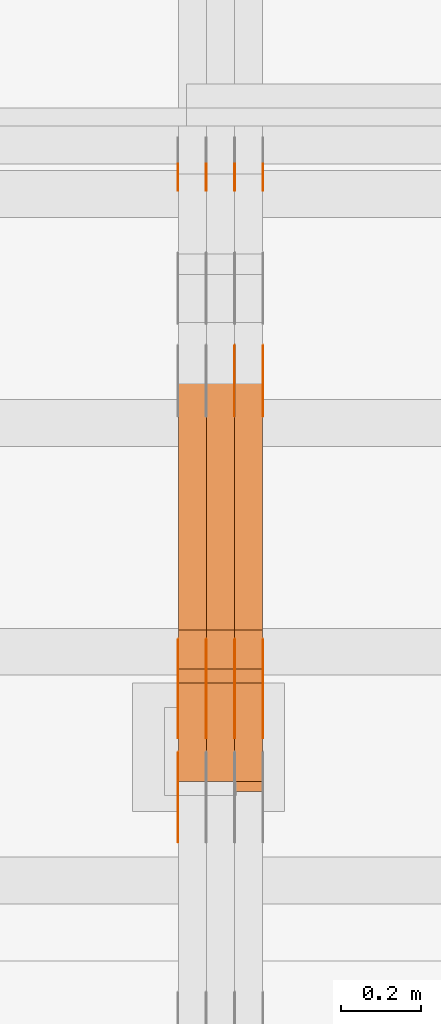
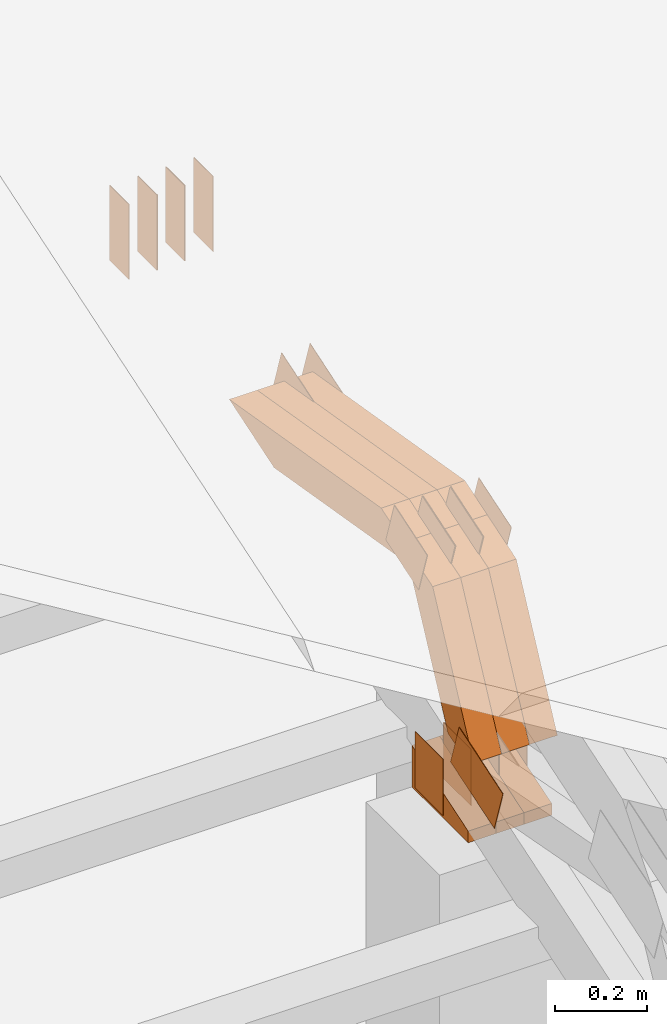
# One storey, part 295 of 385: 30 proxies.
"""IFC2X3 building model written with IfcOpenShell, lengths in millimetres."""

from ifc_helpers import new_model, entity, si_unit, converted_unit, derived_unit, direction, frame, frame_2d, origin, place, context, subcontext, project, spatial, polyline, rectangle, outline, extrude, source, transform, mapped, material, type_object, type_shapes, element, save


model = new_model("IFC2X3")

# Units and contexts
model_context = context("Model", 3, precision=0.01, world=origin(), true_north=direction((6.12303176911189e-17, 1.0)))
body_context = subcontext(model_context, "Body", "Model", "MODEL_VIEW")
ifc_project = project(units=[si_unit("LENGTHUNIT", "METRE", prefix="MILLI"), si_unit("AREAUNIT", "SQUARE_METRE"), si_unit("VOLUMEUNIT", "CUBIC_METRE"), converted_unit("PLANEANGLEUNIT", "DEGREE", entity("IfcRatioMeasure", 0.0174532925199433), si_unit("PLANEANGLEUNIT", "RADIAN"), dimensions=[0, 0, 0, 0, 0, 0, 0]), si_unit("MASSUNIT", "GRAM", prefix="KILO"), derived_unit("MASSDENSITYUNIT", [(si_unit("MASSUNIT", "GRAM", prefix="KILO"), 1), (si_unit("LENGTHUNIT", "METRE"), -3)]), si_unit("TIMEUNIT", "SECOND"), si_unit("FREQUENCYUNIT", "HERTZ"), si_unit("THERMODYNAMICTEMPERATUREUNIT", "DEGREE_CELSIUS"), derived_unit("THERMALTRANSMITTANCEUNIT", [(si_unit("MASSUNIT", "GRAM", prefix="KILO"), 1), (si_unit("THERMODYNAMICTEMPERATUREUNIT", "KELVIN"), -1), (si_unit("TIMEUNIT", "SECOND"), -3)]), derived_unit("VOLUMETRICFLOWRATEUNIT", [(si_unit("LENGTHUNIT", "METRE"), 3), (si_unit("TIMEUNIT", "SECOND"), -1)]), si_unit("ELECTRICCURRENTUNIT", "AMPERE"), si_unit("ELECTRICVOLTAGEUNIT", "VOLT"), si_unit("POWERUNIT", "WATT"), si_unit("FORCEUNIT", "NEWTON", prefix="KILO"), si_unit("ILLUMINANCEUNIT", "LUX"), si_unit("LUMINOUSFLUXUNIT", "LUMEN"), si_unit("LUMINOUSINTENSITYUNIT", "CANDELA"), derived_unit("USERDEFINED", [(si_unit("MASSUNIT", "GRAM", prefix="KILO"), -1), (si_unit("LENGTHUNIT", "METRE"), -2), (si_unit("TIMEUNIT", "SECOND"), 3), (si_unit("LUMINOUSFLUXUNIT", "LUMEN"), 1)]), derived_unit("LINEARVELOCITYUNIT", [(si_unit("LENGTHUNIT", "METRE"), 1), (si_unit("TIMEUNIT", "SECOND"), -1)]), si_unit("PRESSUREUNIT", "PASCAL"), derived_unit("USERDEFINED", [(si_unit("LENGTHUNIT", "METRE"), -2), (si_unit("MASSUNIT", "GRAM", prefix="KILO"), 1), (si_unit("TIMEUNIT", "SECOND"), -2)])], contexts=[model_context])

# Site, building, storey
site_placement = place(None, origin())
site = spatial("IfcSite", under=ifc_project, at=site_placement, CompositionType="ELEMENT")
building_placement = place(site_placement, origin())
building = spatial("IfcBuilding", under=site, at=building_placement, CompositionType="ELEMENT")
storey_placement = place(building_placement, origin())
storey = spatial("IfcBuildingStorey", under=building, at=storey_placement, Name="Default", CompositionType="ELEMENT", Elevation=0.0)

# Proxies
ifc_material_1 = material(Name="IfcSurfaceStyle #519028")
building_element_proxy_type_1 = type_object("IfcBuildingElementProxyType", PredefinedType="NOTDEFINED", material=ifc_material_1)
shared_shape_1 = source(origin(), body_context, "Body", "SweptSolid", [
    extrude(rectangle(XDim=200.0, YDim=84.0, at=frame_2d((0.0, -7.105427357601e-15), x_axis=(1.0, 0.0))), frame((100.0, 42.0, 0.0), z_axis=(0.0, 0.0, 1.0), x_axis=(-1.0, 0.0, 0.0)), (0.0, 0.0, 1.0), 1.3),
])
type_shapes(building_element_proxy_type_1, [shared_shape_1])
proxy_1_placement = place(building_placement, frame((42386.3, 13702.0, 3651.4150390625), z_axis=(-1.0, 0.0, 0.0), x_axis=(0.0, 0.0, -1.0)))
element("IfcBuildingElementProxy", 1, at=proxy_1_placement, inside=storey, type_object=building_element_proxy_type_1, material=ifc_material_1, context=body_context, shape_type="MappedRepresentation", body=[
    mapped(shared_shape_1, transform((0.0, 0.0, 0.0), scale=1.0)),
])
ifc_material_2 = material(Name="IfcSurfaceStyle #518971")
building_element_proxy_type_2 = type_object("IfcBuildingElementProxyType", PredefinedType="NOTDEFINED", material=ifc_material_2)
shared_shape_2 = source(origin(), body_context, "Body", "SweptSolid", [
    extrude(rectangle(XDim=200.0, YDim=84.0, at=frame_2d((0.0, -7.105427357601e-15), x_axis=(1.0, 0.0))), frame((100.0, 42.0, 0.0), z_axis=(0.0, 0.0, 1.0), x_axis=(-1.0, 0.0, 0.0)), (0.0, 0.0, 1.0), 1.3),
])
type_shapes(building_element_proxy_type_2, [shared_shape_2])
proxy_2_placement = place(building_placement, frame((42315.0, 13702.0, 3651.4150390625), z_axis=(-1.0, 0.0, 0.0), x_axis=(0.0, 0.0, -1.0)))
element("IfcBuildingElementProxy", 2, at=proxy_2_placement, inside=storey, type_object=building_element_proxy_type_2, material=ifc_material_2, context=body_context, shape_type="MappedRepresentation", body=[
    mapped(shared_shape_2, transform((0.0, 0.0, 0.0), scale=1.0)),
])
ifc_material_3 = material(Name="IfcSurfaceStyle #518914")
building_element_proxy_type_3 = type_object("IfcBuildingElementProxyType", PredefinedType="NOTDEFINED", material=ifc_material_3)
shared_shape_3 = source(origin(), body_context, "Body", "SweptSolid", [
    extrude(rectangle(XDim=200.0, YDim=84.0, at=frame_2d((0.0, -7.105427357601e-15), x_axis=(1.0, 0.0))), frame((100.0, 42.0, 0.0), z_axis=(0.0, 0.0, 1.0), x_axis=(-1.0, 0.0, 0.0)), (0.0, 0.0, 1.0), 1.3),
])
type_shapes(building_element_proxy_type_3, [shared_shape_3])
proxy_3_placement = place(building_placement, frame((42316.3, 13702.0, 3651.4150390625), z_axis=(-1.0, 0.0, 0.0), x_axis=(0.0, 0.0, -1.0)))
element("IfcBuildingElementProxy", 3, at=proxy_3_placement, inside=storey, type_object=building_element_proxy_type_3, material=ifc_material_3, context=body_context, shape_type="MappedRepresentation", body=[
    mapped(shared_shape_3, transform((0.0, 0.0, 0.0), scale=1.0)),
])
ifc_material_4 = material(Name="IfcSurfaceStyle #518857")
building_element_proxy_type_4 = type_object("IfcBuildingElementProxyType", PredefinedType="NOTDEFINED", material=ifc_material_4)
shared_shape_4 = source(origin(), body_context, "Body", "SweptSolid", [
    extrude(rectangle(XDim=200.0, YDim=84.0, at=frame_2d((0.0, -7.105427357601e-15), x_axis=(1.0, 0.0))), frame((100.0, 42.0, 0.0), z_axis=(0.0, 0.0, 1.0), x_axis=(-1.0, 0.0, 0.0)), (0.0, 0.0, 1.0), 1.29999999999998),
])
type_shapes(building_element_proxy_type_4, [shared_shape_4])
proxy_4_placement = place(building_placement, frame((42245.0, 13702.0, 3651.4150390625), z_axis=(-1.0, 0.0, 0.0), x_axis=(0.0, 0.0, -1.0)))
element("IfcBuildingElementProxy", 4, at=proxy_4_placement, inside=storey, type_object=building_element_proxy_type_4, material=ifc_material_4, context=body_context, shape_type="MappedRepresentation", body=[
    mapped(shared_shape_4, transform((0.0, 0.0, 0.0), scale=1.0)),
])
ifc_material_5 = material(Name="IfcSurfaceStyle #518800")
building_element_proxy_type_5 = type_object("IfcBuildingElementProxyType", PredefinedType="NOTDEFINED", material=ifc_material_5)
shared_shape_5 = source(origin(), body_context, "Body", "SweptSolid", [
    extrude(rectangle(XDim=200.0, YDim=84.0, at=frame_2d((0.0, -7.105427357601e-15), x_axis=(1.0, 0.0))), frame((100.0, 42.0, 0.0), z_axis=(0.0, 0.0, 1.0), x_axis=(-1.0, 0.0, 0.0)), (0.0, 0.0, 1.0), 1.29999999999998),
])
type_shapes(building_element_proxy_type_5, [shared_shape_5])
proxy_5_placement = place(building_placement, frame((42246.3, 13702.0, 3651.4150390625), z_axis=(-1.0, 0.0, 0.0), x_axis=(0.0, 0.0, -1.0)))
element("IfcBuildingElementProxy", 5, at=proxy_5_placement, inside=storey, type_object=building_element_proxy_type_5, material=ifc_material_5, context=body_context, shape_type="MappedRepresentation", body=[
    mapped(shared_shape_5, transform((0.0, 0.0, 0.0), scale=1.0)),
])
ifc_material_6 = material(Name="IfcSurfaceStyle #518743")
building_element_proxy_type_6 = type_object("IfcBuildingElementProxyType", PredefinedType="NOTDEFINED", material=ifc_material_6)
shared_shape_6 = source(origin(), body_context, "Body", "SweptSolid", [
    extrude(rectangle(XDim=200.0, YDim=84.0, at=frame_2d((0.0, -7.105427357601e-15), x_axis=(1.0, 0.0))), frame((100.0, 42.0, 0.0), z_axis=(0.0, 0.0, 1.0), x_axis=(-1.0, 0.0, 0.0)), (0.0, 0.0, 1.0), 1.29999999999999),
])
type_shapes(building_element_proxy_type_6, [shared_shape_6])
proxy_6_placement = place(building_placement, frame((42175.0, 13702.0, 3651.4150390625), z_axis=(-1.0, 0.0, 0.0), x_axis=(0.0, 0.0, -1.0)))
element("IfcBuildingElementProxy", 6, at=proxy_6_placement, inside=storey, type_object=building_element_proxy_type_6, material=ifc_material_6, context=body_context, shape_type="MappedRepresentation", body=[
    mapped(shared_shape_6, transform((0.0, 0.0, 0.0), scale=1.0)),
])
ifc_material_7 = material(Name="IfcSurfaceStyle #518686")
building_element_proxy_type_7 = type_object("IfcBuildingElementProxyType", PredefinedType="NOTDEFINED", material=ifc_material_7)
shared_shape_7 = source(origin(), body_context, "Body", "SweptSolid", [
    extrude(outline(polyline([(-75.0003398116828, -59.9998507501386), (75.0003249421766, -59.9998507501386), (75.0003398116837, 59.9998507501387), (-75.0003249421775, 59.9998507501387), (-75.0003398116828, -59.9998507501386)])), frame((75.0003398116837, 60.0000773549637, 0.0), z_axis=(0.0, 0.0, 1.0), x_axis=(-1.0, 0.0, 0.0)), (0.0, 0.0, 1.0), 1.3),
])
type_shapes(building_element_proxy_type_7, [shared_shape_7])
proxy_7_placement = place(building_placement, frame((42386.3, 13054.73046875, 3417.8388671875), z_axis=(-1.0, 0.0, 0.0), x_axis=(0.0, 0.951056516295124, 0.309016994375039)))
element("IfcBuildingElementProxy", 7, at=proxy_7_placement, inside=storey, type_object=building_element_proxy_type_7, material=ifc_material_7, context=body_context, shape_type="MappedRepresentation", body=[
    mapped(shared_shape_7, transform((0.0, 0.0, 0.0), scale=1.0)),
])
ifc_material_8 = material(Name="IfcSurfaceStyle #518629")
building_element_proxy_type_8 = type_object("IfcBuildingElementProxyType", PredefinedType="NOTDEFINED", material=ifc_material_8)
shared_shape_8 = source(origin(), body_context, "Body", "SweptSolid", [
    extrude(outline(polyline([(-75.0003398116828, -59.9998507501386), (75.0003249421766, -59.9998507501386), (75.0003398116837, 59.9998507501387), (-75.0003249421775, 59.9998507501387), (-75.0003398116828, -59.9998507501386)])), frame((75.0003398116837, 60.0000773549637, 0.0), z_axis=(0.0, 0.0, 1.0), x_axis=(-1.0, 0.0, 0.0)), (0.0, 0.0, 1.0), 1.3),
])
type_shapes(building_element_proxy_type_8, [shared_shape_8])
proxy_8_placement = place(building_placement, frame((42315.0, 13054.73046875, 3417.8388671875), z_axis=(-1.0, 0.0, 0.0), x_axis=(0.0, 0.951056516295124, 0.309016994375039)))
element("IfcBuildingElementProxy", 8, at=proxy_8_placement, inside=storey, type_object=building_element_proxy_type_8, material=ifc_material_8, context=body_context, shape_type="MappedRepresentation", body=[
    mapped(shared_shape_8, transform((0.0, 0.0, 0.0), scale=1.0)),
])
ifc_material_9 = material(Name="IfcSurfaceStyle #516691")
building_element_proxy_type_9 = type_object("IfcBuildingElementProxyType", PredefinedType="NOTDEFINED", material=ifc_material_9)
shared_shape_9 = source(origin(), body_context, "Body", "SweptSolid", [
    extrude(outline(polyline([(-99.9997874178038, -60.0000528641967), (99.9998102700997, -60.0000528641967), (99.9998251396068, 60.0000528641967), (-99.9998479919027, 60.0000528641967), (-99.9997874178038, -60.0000528641967)])), frame((99.9999918898597, 60.0000528641967, 0.0), z_axis=(0.0, 0.0, 1.0), x_axis=(-1.0, 0.0, 0.0)), (0.0, 0.0, 1.0), 1.29999999999999),
])
type_shapes(building_element_proxy_type_9, [shared_shape_9])
proxy_9_placement = place(building_placement, frame((42175.0, 11991.9568177725, 3072.52282247925), z_axis=(-1.0, 0.0, 0.0), x_axis=(0.0, 0.951056516295124, 0.309016994375039)))
element("IfcBuildingElementProxy", 9, at=proxy_9_placement, inside=storey, type_object=building_element_proxy_type_9, material=ifc_material_9, context=body_context, shape_type="MappedRepresentation", body=[
    mapped(shared_shape_9, transform((0.0, 0.0, 0.0), scale=1.0)),
])
ifc_material_10 = material(Name="IfcSurfaceStyle #516634")
building_element_proxy_type_10 = type_object("IfcBuildingElementProxyType", PredefinedType="NOTDEFINED", material=ifc_material_10)
shared_shape_10 = source(origin(), body_context, "Body", "SweptSolid", [
    extrude(rectangle(XDim=150.0, YDim=119.999999999985, at=frame_2d((-7.105427357601e-15, 0.0), x_axis=(1.0, 0.0))), frame((75.0, 60.0, 0.0), z_axis=(0.0, 0.0, 1.0), x_axis=(-1.0, 0.0, 0.0)), (0.0, 0.0, 1.0), 1.3),
])
type_shapes(building_element_proxy_type_10, [shared_shape_10])
proxy_10_placement = place(building_placement, frame((42386.3, 12372.95703125, 3007.04687500001), z_axis=(-1.0, 0.0, 0.0), x_axis=(0.0, 0.0, -1.0)))
element("IfcBuildingElementProxy", 10, at=proxy_10_placement, inside=storey, type_object=building_element_proxy_type_10, material=ifc_material_10, context=body_context, shape_type="MappedRepresentation", body=[
    mapped(shared_shape_10, transform((0.0, 0.0, 0.0), scale=1.0)),
])
ifc_material_11 = material(Name="IfcSurfaceStyle #516577")
building_element_proxy_type_11 = type_object("IfcBuildingElementProxyType", PredefinedType="NOTDEFINED", material=ifc_material_11)
shared_shape_11 = source(origin(), body_context, "Body", "SweptSolid", [
    extrude(rectangle(XDim=150.0, YDim=119.999999999985, at=frame_2d((-7.105427357601e-15, 0.0), x_axis=(1.0, 0.0))), frame((75.0, 60.0, 0.0), z_axis=(0.0, 0.0, 1.0), x_axis=(-1.0, 0.0, 0.0)), (0.0, 0.0, 1.0), 1.3),
])
type_shapes(building_element_proxy_type_11, [shared_shape_11])
proxy_11_placement = place(building_placement, frame((42315.0, 12372.95703125, 3007.04687500001), z_axis=(-1.0, 0.0, 0.0), x_axis=(0.0, 0.0, -1.0)))
element("IfcBuildingElementProxy", 11, at=proxy_11_placement, inside=storey, type_object=building_element_proxy_type_11, material=ifc_material_11, context=body_context, shape_type="MappedRepresentation", body=[
    mapped(shared_shape_11, transform((0.0, 0.0, 0.0), scale=1.0)),
])
ifc_material_12 = material(Name="IfcSurfaceStyle #516520")
building_element_proxy_type_12 = type_object("IfcBuildingElementProxyType", PredefinedType="NOTDEFINED", material=ifc_material_12)
shared_shape_12 = source(origin(), body_context, "Body", "SweptSolid", [
    extrude(rectangle(XDim=150.0, YDim=119.999999999985, at=frame_2d((-7.105427357601e-15, 0.0), x_axis=(1.0, 0.0))), frame((75.0, 60.0, 0.0), z_axis=(0.0, 0.0, 1.0), x_axis=(-1.0, 0.0, 0.0)), (0.0, 0.0, 1.0), 1.3),
])
type_shapes(building_element_proxy_type_12, [shared_shape_12])
proxy_12_placement = place(building_placement, frame((42316.3, 12372.95703125, 3007.04687500001), z_axis=(-1.0, 0.0, 0.0), x_axis=(0.0, 0.0, -1.0)))
element("IfcBuildingElementProxy", 12, at=proxy_12_placement, inside=storey, type_object=building_element_proxy_type_12, material=ifc_material_12, context=body_context, shape_type="MappedRepresentation", body=[
    mapped(shared_shape_12, transform((0.0, 0.0, 0.0), scale=1.0)),
])
ifc_material_13 = material(Name="IfcSurfaceStyle #516463")
building_element_proxy_type_13 = type_object("IfcBuildingElementProxyType", PredefinedType="NOTDEFINED", material=ifc_material_13)
shared_shape_13 = source(origin(), body_context, "Body", "SweptSolid", [
    extrude(rectangle(XDim=150.0, YDim=119.999999999985, at=frame_2d((-7.105427357601e-15, 0.0), x_axis=(1.0, 0.0))), frame((75.0, 60.0, 0.0), z_axis=(0.0, 0.0, 1.0), x_axis=(-1.0, 0.0, 0.0)), (0.0, 0.0, 1.0), 1.29999999999999),
])
type_shapes(building_element_proxy_type_13, [shared_shape_13])
proxy_13_placement = place(building_placement, frame((42245.0, 12372.95703125, 3007.04687500001), z_axis=(-1.0, 0.0, 0.0), x_axis=(0.0, 0.0, -1.0)))
element("IfcBuildingElementProxy", 13, at=proxy_13_placement, inside=storey, type_object=building_element_proxy_type_13, material=ifc_material_13, context=body_context, shape_type="MappedRepresentation", body=[
    mapped(shared_shape_13, transform((0.0, 0.0, 0.0), scale=1.0)),
])
ifc_material_14 = material(Name="IfcSurfaceStyle #516406")
building_element_proxy_type_14 = type_object("IfcBuildingElementProxyType", PredefinedType="NOTDEFINED", material=ifc_material_14)
shared_shape_14 = source(origin(), body_context, "Body", "SweptSolid", [
    extrude(rectangle(XDim=150.0, YDim=119.999999999985, at=frame_2d((-7.105427357601e-15, 0.0), x_axis=(1.0, 0.0))), frame((75.0, 60.0, 0.0), z_axis=(0.0, 0.0, 1.0), x_axis=(-1.0, 0.0, 0.0)), (0.0, 0.0, 1.0), 1.29999999999999),
])
type_shapes(building_element_proxy_type_14, [shared_shape_14])
proxy_14_placement = place(building_placement, frame((42246.3, 12372.95703125, 3007.04687500001), z_axis=(-1.0, 0.0, 0.0), x_axis=(0.0, 0.0, -1.0)))
element("IfcBuildingElementProxy", 14, at=proxy_14_placement, inside=storey, type_object=building_element_proxy_type_14, material=ifc_material_14, context=body_context, shape_type="MappedRepresentation", body=[
    mapped(shared_shape_14, transform((0.0, 0.0, 0.0), scale=1.0)),
])
ifc_material_15 = material(Name="IfcSurfaceStyle #516349")
building_element_proxy_type_15 = type_object("IfcBuildingElementProxyType", PredefinedType="NOTDEFINED", material=ifc_material_15)
shared_shape_15 = source(origin(), body_context, "Body", "SweptSolid", [
    extrude(rectangle(XDim=150.0, YDim=119.999999999985, at=frame_2d((-7.105427357601e-15, 0.0), x_axis=(1.0, 0.0))), frame((75.0, 60.0, 0.0), z_axis=(0.0, 0.0, 1.0), x_axis=(-1.0, 0.0, 0.0)), (0.0, 0.0, 1.0), 1.29999999999999),
])
type_shapes(building_element_proxy_type_15, [shared_shape_15])
proxy_15_placement = place(building_placement, frame((42175.0, 12372.95703125, 3007.04687500001), z_axis=(-1.0, 0.0, 0.0), x_axis=(0.0, 0.0, -1.0)))
element("IfcBuildingElementProxy", 15, at=proxy_15_placement, inside=storey, type_object=building_element_proxy_type_15, material=ifc_material_15, context=body_context, shape_type="MappedRepresentation", body=[
    mapped(shared_shape_15, transform((0.0, 0.0, 0.0), scale=1.0)),
])
ifc_material_16 = material(Name="IfcSurfaceStyle #509452")
building_element_proxy_type_16 = type_object("IfcBuildingElementProxyType", PredefinedType="NOTDEFINED", material=ifc_material_16)
shared_shape_16 = source(origin(), body_context, "Body", "SweptSolid", [
    extrude(outline(polyline([(-74.9998754286244, -60.0000016373506), (74.9998605591063, -60.0000016373506), (74.9998754286244, 60.0000016373506), (-74.9998605591063, 60.0000016373506), (-74.9998754286244, -60.0000016373506)])), frame((74.9998754286244, 60.0000016373506, 0.0), z_axis=(0.0, 0.0, 1.0), x_axis=(-1.0, 0.0, 0.0)), (0.0, 0.0, 1.0), 1.3),
])
type_shapes(building_element_proxy_type_16, [shared_shape_16])
proxy_16_placement = place(building_placement, frame((42386.3, 12321.1620861463, 3506.17707344366), z_axis=(-1.0, 0.0, 0.0), x_axis=(0.0, 0.951056516295154, 0.309016994374948)))
element("IfcBuildingElementProxy", 16, at=proxy_16_placement, inside=storey, type_object=building_element_proxy_type_16, material=ifc_material_16, context=body_context, shape_type="MappedRepresentation", body=[
    mapped(shared_shape_16, transform((0.0, 0.0, 0.0), scale=1.0)),
])
ifc_material_17 = material(Name="IfcSurfaceStyle #509395")
building_element_proxy_type_17 = type_object("IfcBuildingElementProxyType", PredefinedType="NOTDEFINED", material=ifc_material_17)
shared_shape_17 = source(origin(), body_context, "Body", "SweptSolid", [
    extrude(outline(polyline([(-74.9998754286244, -60.0000016373506), (74.9998605591063, -60.0000016373506), (74.9998754286244, 60.0000016373506), (-74.9998605591063, 60.0000016373506), (-74.9998754286244, -60.0000016373506)])), frame((74.9998754286244, 60.0000016373506, 0.0), z_axis=(0.0, 0.0, 1.0), x_axis=(-1.0, 0.0, 0.0)), (0.0, 0.0, 1.0), 1.3),
])
type_shapes(building_element_proxy_type_17, [shared_shape_17])
proxy_17_placement = place(building_placement, frame((42315.0, 12321.1620861463, 3506.17707344366), z_axis=(-1.0, 0.0, 0.0), x_axis=(0.0, 0.951056516295154, 0.309016994374948)))
element("IfcBuildingElementProxy", 17, at=proxy_17_placement, inside=storey, type_object=building_element_proxy_type_17, material=ifc_material_17, context=body_context, shape_type="MappedRepresentation", body=[
    mapped(shared_shape_17, transform((0.0, 0.0, 0.0), scale=1.0)),
])
ifc_material_18 = material(Name="IfcSurfaceStyle #509338")
building_element_proxy_type_18 = type_object("IfcBuildingElementProxyType", PredefinedType="NOTDEFINED", material=ifc_material_18)
shared_shape_18 = source(origin(), body_context, "Body", "SweptSolid", [
    extrude(outline(polyline([(-74.9998754286244, -60.0000016373506), (74.9998605591063, -60.0000016373506), (74.9998754286244, 60.0000016373506), (-74.9998605591063, 60.0000016373506), (-74.9998754286244, -60.0000016373506)])), frame((74.9998754286244, 60.0000016373506, 0.0), z_axis=(0.0, 0.0, 1.0), x_axis=(-1.0, 0.0, 0.0)), (0.0, 0.0, 1.0), 1.3),
])
type_shapes(building_element_proxy_type_18, [shared_shape_18])
proxy_18_placement = place(building_placement, frame((42316.3, 12321.1620861463, 3506.17707344366), z_axis=(-1.0, 0.0, 0.0), x_axis=(0.0, 0.951056516295154, 0.309016994374948)))
element("IfcBuildingElementProxy", 18, at=proxy_18_placement, inside=storey, type_object=building_element_proxy_type_18, material=ifc_material_18, context=body_context, shape_type="MappedRepresentation", body=[
    mapped(shared_shape_18, transform((0.0, 0.0, 0.0), scale=1.0)),
])
ifc_material_19 = material(Name="IfcSurfaceStyle #509281")
building_element_proxy_type_19 = type_object("IfcBuildingElementProxyType", PredefinedType="NOTDEFINED", material=ifc_material_19)
shared_shape_19 = source(origin(), body_context, "Body", "SweptSolid", [
    extrude(outline(polyline([(-74.9998754286244, -60.0000016373506), (74.9998605591063, -60.0000016373506), (74.9998754286244, 60.0000016373506), (-74.9998605591063, 60.0000016373506), (-74.9998754286244, -60.0000016373506)])), frame((74.9998754286244, 60.0000016373506, 0.0), z_axis=(0.0, 0.0, 1.0), x_axis=(-1.0, 0.0, 0.0)), (0.0, 0.0, 1.0), 1.29999999999999),
])
type_shapes(building_element_proxy_type_19, [shared_shape_19])
proxy_19_placement = place(building_placement, frame((42245.0, 12321.1620861463, 3506.17707344366), z_axis=(-1.0, 0.0, 0.0), x_axis=(0.0, 0.951056516295154, 0.309016994374948)))
element("IfcBuildingElementProxy", 19, at=proxy_19_placement, inside=storey, type_object=building_element_proxy_type_19, material=ifc_material_19, context=body_context, shape_type="MappedRepresentation", body=[
    mapped(shared_shape_19, transform((0.0, 0.0, 0.0), scale=1.0)),
])
ifc_material_20 = material(Name="IfcSurfaceStyle #509224")
building_element_proxy_type_20 = type_object("IfcBuildingElementProxyType", PredefinedType="NOTDEFINED", material=ifc_material_20)
shared_shape_20 = source(origin(), body_context, "Body", "SweptSolid", [
    extrude(outline(polyline([(-74.9998754286244, -60.0000016373506), (74.9998605591063, -60.0000016373506), (74.9998754286244, 60.0000016373506), (-74.9998605591063, 60.0000016373506), (-74.9998754286244, -60.0000016373506)])), frame((74.9998754286244, 60.0000016373506, 0.0), z_axis=(0.0, 0.0, 1.0), x_axis=(-1.0, 0.0, 0.0)), (0.0, 0.0, 1.0), 1.29999999999999),
])
type_shapes(building_element_proxy_type_20, [shared_shape_20])
proxy_20_placement = place(building_placement, frame((42246.3, 12321.1620861463, 3506.17707344366), z_axis=(-1.0, 0.0, 0.0), x_axis=(0.0, 0.951056516295154, 0.309016994374948)))
element("IfcBuildingElementProxy", 20, at=proxy_20_placement, inside=storey, type_object=building_element_proxy_type_20, material=ifc_material_20, context=body_context, shape_type="MappedRepresentation", body=[
    mapped(shared_shape_20, transform((0.0, 0.0, 0.0), scale=1.0)),
])
ifc_material_21 = material(Name="IfcSurfaceStyle #509167")
building_element_proxy_type_21 = type_object("IfcBuildingElementProxyType", PredefinedType="NOTDEFINED", material=ifc_material_21)
shared_shape_21 = source(origin(), body_context, "Body", "SweptSolid", [
    extrude(outline(polyline([(-74.9998754286244, -60.0000016373506), (74.9998605591063, -60.0000016373506), (74.9998754286244, 60.0000016373506), (-74.9998605591063, 60.0000016373506), (-74.9998754286244, -60.0000016373506)])), frame((74.9998754286244, 60.0000016373506, 0.0), z_axis=(0.0, 0.0, 1.0), x_axis=(-1.0, 0.0, 0.0)), (0.0, 0.0, 1.0), 1.29999999999999),
])
type_shapes(building_element_proxy_type_21, [shared_shape_21])
proxy_21_placement = place(building_placement, frame((42175.0, 12321.1620861463, 3506.17707344366), z_axis=(-1.0, 0.0, 0.0), x_axis=(0.0, 0.951056516295154, 0.309016994374948)))
element("IfcBuildingElementProxy", 21, at=proxy_21_placement, inside=storey, type_object=building_element_proxy_type_21, material=ifc_material_21, context=body_context, shape_type="MappedRepresentation", body=[
    mapped(shared_shape_21, transform((0.0, 0.0, 0.0), scale=1.0)),
])
ifc_material_22 = material(Name="IfcSurfaceStyle #500992")
building_element_proxy_type_22 = type_object("IfcBuildingElementProxyType", Name="T1-E1 500990", PredefinedType="NOTDEFINED", material=ifc_material_22)
shared_shape_22 = source(origin(), body_context, "Body", "SweptSolid", [
    extrude(outline(polyline([(-75.1378173828004, -122.500000000005), (35.3350830078246, -122.500000000005), (35.3350830078004, 122.500000000005), (4.46765136717545, 122.500000000005), (-75.1378173828004, -122.500000000005)])), frame((35.3350830078246, 122.500000104877, 0.0), z_axis=(0.0, 0.0, 1.0), x_axis=(-1.0, 0.0, 0.0)), (0.0, 0.0, 1.0), 70.0),
])
type_shapes(building_element_proxy_type_22, [shared_shape_22])
proxy_22_placement = place(building_placement, frame((42385.0, 12145.0, 2849.54565429685), z_axis=(-1.0, 0.0, 0.0), x_axis=(0.0, 0.0, 1.0)))
element("IfcBuildingElementProxy", 22, at=proxy_22_placement, inside=storey, type_object=building_element_proxy_type_22, material=ifc_material_22, Name="T1-E1", context=body_context, shape_type="MappedRepresentation", body=[
    mapped(shared_shape_22, transform((0.0, 0.0, 0.0), scale=1.0)),
])
ifc_material_23 = material(Name="IfcSurfaceStyle #500935")
building_element_proxy_type_23 = type_object("IfcBuildingElementProxyType", Name="T1-E1 500933", PredefinedType="NOTDEFINED", material=ifc_material_23)
shared_shape_23 = source(origin(), body_context, "Body", "SweptSolid", [
    extrude(outline(polyline([(-75.1378173828004, -122.500000000005), (35.3350830078246, -122.500000000005), (35.3350830078004, 122.500000000005), (4.46765136717545, 122.500000000005), (-75.1378173828004, -122.500000000005)])), frame((35.3350830078246, 122.500000104877, 0.0), z_axis=(0.0, 0.0, 1.0), x_axis=(-1.0, 0.0, 0.0)), (0.0, 0.0, 1.0), 70.0),
])
type_shapes(building_element_proxy_type_23, [shared_shape_23])
proxy_23_placement = place(building_placement, frame((42315.0, 12145.0, 2849.54565429685), z_axis=(-1.0, 0.0, 0.0), x_axis=(0.0, 0.0, 1.0)))
element("IfcBuildingElementProxy", 23, at=proxy_23_placement, inside=storey, type_object=building_element_proxy_type_23, material=ifc_material_23, Name="T1-E1", context=body_context, shape_type="MappedRepresentation", body=[
    mapped(shared_shape_23, transform((0.0, 0.0, 0.0), scale=1.0)),
])
ifc_material_24 = material(Name="IfcSurfaceStyle #500878")
building_element_proxy_type_24 = type_object("IfcBuildingElementProxyType", Name="T1-E1 500876", PredefinedType="NOTDEFINED", material=ifc_material_24)
shared_shape_24 = source(origin(), body_context, "Body", "SweptSolid", [
    extrude(outline(polyline([(-75.1378173828004, -122.500000000005), (35.3350830078246, -122.500000000005), (35.3350830078004, 122.500000000005), (4.46765136717545, 122.500000000005), (-75.1378173828004, -122.500000000005)])), frame((35.3350830078246, 122.500000104877, 0.0), z_axis=(0.0, 0.0, 1.0), x_axis=(-1.0, 0.0, 0.0)), (0.0, 0.0, 1.0), 70.0),
])
type_shapes(building_element_proxy_type_24, [shared_shape_24])
proxy_24_placement = place(building_placement, frame((42245.0, 12145.0, 2849.54565429685), z_axis=(-1.0, 0.0, 0.0), x_axis=(0.0, 0.0, 1.0)))
element("IfcBuildingElementProxy", 24, at=proxy_24_placement, inside=storey, type_object=building_element_proxy_type_24, material=ifc_material_24, Name="T1-E1", context=body_context, shape_type="MappedRepresentation", body=[
    mapped(shared_shape_24, transform((0.0, 0.0, 0.0), scale=1.0)),
])
ifc_material_25 = material(Name="IfcSurfaceStyle #499264")
building_element_proxy_type_25 = type_object("IfcBuildingElementProxyType", Name="T1-W7 499262", PredefinedType="NOTDEFINED", material=ifc_material_25)
shared_shape_25 = source(origin(), body_context, "Body", "SweptSolid", [
    extrude(outline(polyline([(-296.174043820986, -47.5000676566704), (297.841254477443, -47.5000676566704), (283.518570346415, -7.10254316533821e-06), (192.674144473719, 47.500071207942), (-477.859925476591, 47.500071207942), (-296.174043820986, -47.5000676566704)])), frame((297.841254477443, 47.5000816097442, 0.0), z_axis=(0.0, 0.0, 1.0), x_axis=(-1.0, 0.0, 0.0)), (0.0, 0.0, 1.0), 70.0),
])
type_shapes(building_element_proxy_type_25, [shared_shape_25])
proxy_25_placement = place(building_placement, frame((42385.0, 12419.2991208897, 3526.2136755972), z_axis=(-1.0, 0.0, 0.0), x_axis=(0.0, 0.985983815111804, -0.166840991178939)))
element("IfcBuildingElementProxy", 25, at=proxy_25_placement, inside=storey, type_object=building_element_proxy_type_25, material=ifc_material_25, Name="T1-W7", context=body_context, shape_type="MappedRepresentation", body=[
    mapped(shared_shape_25, transform((0.0, 0.0, 0.0), scale=1.0)),
])
ifc_material_26 = material(Name="IfcSurfaceStyle #499198")
building_element_proxy_type_26 = type_object("IfcBuildingElementProxyType", Name="T1-W7 499196", PredefinedType="NOTDEFINED", material=ifc_material_26)
shared_shape_26 = source(origin(), body_context, "Body", "SweptSolid", [
    extrude(outline(polyline([(-296.174043820986, -47.5000676566704), (297.841254477443, -47.5000676566704), (283.518570346415, -7.10254316533821e-06), (192.674144473719, 47.500071207942), (-477.859925476591, 47.500071207942), (-296.174043820986, -47.5000676566704)])), frame((297.841254477443, 47.5000816097442, 0.0), z_axis=(0.0, 0.0, 1.0), x_axis=(-1.0, 0.0, 0.0)), (0.0, 0.0, 1.0), 70.0),
])
type_shapes(building_element_proxy_type_26, [shared_shape_26])
proxy_26_placement = place(building_placement, frame((42315.0, 12419.2991208897, 3526.2136755972), z_axis=(-1.0, 0.0, 0.0), x_axis=(0.0, 0.985983815111804, -0.166840991178939)))
element("IfcBuildingElementProxy", 26, at=proxy_26_placement, inside=storey, type_object=building_element_proxy_type_26, material=ifc_material_26, Name="T1-W7", context=body_context, shape_type="MappedRepresentation", body=[
    mapped(shared_shape_26, transform((0.0, 0.0, 0.0), scale=1.0)),
])
ifc_material_27 = material(Name="IfcSurfaceStyle #499132")
building_element_proxy_type_27 = type_object("IfcBuildingElementProxyType", Name="T1-W7 499130", PredefinedType="NOTDEFINED", material=ifc_material_27)
shared_shape_27 = source(origin(), body_context, "Body", "SweptSolid", [
    extrude(outline(polyline([(-296.174043820986, -47.5000676566704), (297.841254477443, -47.5000676566704), (283.518570346415, -7.10254316533821e-06), (192.674144473719, 47.500071207942), (-477.859925476591, 47.500071207942), (-296.174043820986, -47.5000676566704)])), frame((297.841254477443, 47.5000816097442, 0.0), z_axis=(0.0, 0.0, 1.0), x_axis=(-1.0, 0.0, 0.0)), (0.0, 0.0, 1.0), 70.0),
])
type_shapes(building_element_proxy_type_27, [shared_shape_27])
proxy_27_placement = place(building_placement, frame((42245.0, 12419.2991208897, 3526.2136755972), z_axis=(-1.0, 0.0, 0.0), x_axis=(0.0, 0.985983815111804, -0.166840991178939)))
element("IfcBuildingElementProxy", 27, at=proxy_27_placement, inside=storey, type_object=building_element_proxy_type_27, material=ifc_material_27, Name="T1-W7", context=body_context, shape_type="MappedRepresentation", body=[
    mapped(shared_shape_27, transform((0.0, 0.0, 0.0), scale=1.0)),
])
ifc_material_28 = material(Name="IfcSurfaceStyle #498868")
building_element_proxy_type_28 = type_object("IfcBuildingElementProxyType", Name="T1-W36 498866", PredefinedType="NOTDEFINED", material=ifc_material_28)
shared_shape_28 = source(origin(), body_context, "Body", "SweptSolid", [
    extrude(outline(polyline([(-300.714670922549, -47.4998881108849), (134.031527004269, -47.499888110885), (180.52054953879, -0.000136170977331764), (193.89900152221, 47.500563476126), (-207.736407142719, 47.4993489166213), (-300.714670922549, -47.4998881108849)])), frame((193.899145164686, 47.5001861375837, 0.0), z_axis=(0.0, 0.0, 1.0), x_axis=(-1.0, 3.02403492980632e-06, 0.0)), (0.0, 0.0, 1.0), 70.0),
])
type_shapes(building_element_proxy_type_28, [shared_shape_28])
proxy_28_placement = place(building_placement, frame((42385.0, 12120.5935627532, 3076.1128858536), z_axis=(-1.0, 0.0, 0.0), x_axis=(0.0, 0.444384650266842, 0.895836080210669)))
element("IfcBuildingElementProxy", 28, at=proxy_28_placement, inside=storey, type_object=building_element_proxy_type_28, material=ifc_material_28, Name="T1-W36", context=body_context, shape_type="MappedRepresentation", body=[
    mapped(shared_shape_28, transform((0.0, 0.0, 0.0), scale=1.0)),
])
ifc_material_29 = material(Name="IfcSurfaceStyle #498802")
building_element_proxy_type_29 = type_object("IfcBuildingElementProxyType", Name="T1-W36 498800", PredefinedType="NOTDEFINED", material=ifc_material_29)
shared_shape_29 = source(origin(), body_context, "Body", "SweptSolid", [
    extrude(outline(polyline([(-300.714670922549, -47.4998881108849), (134.031527004269, -47.499888110885), (180.52054953879, -0.000136170977331764), (193.89900152221, 47.500563476126), (-207.736407142719, 47.4993489166213), (-300.714670922549, -47.4998881108849)])), frame((193.899145164686, 47.5001861375837, 0.0), z_axis=(0.0, 0.0, 1.0), x_axis=(-1.0, 3.02403492980632e-06, 0.0)), (0.0, 0.0, 1.0), 70.0),
])
type_shapes(building_element_proxy_type_29, [shared_shape_29])
proxy_29_placement = place(building_placement, frame((42315.0, 12120.5935627532, 3076.1128858536), z_axis=(-1.0, 0.0, 0.0), x_axis=(0.0, 0.444384650266842, 0.895836080210669)))
element("IfcBuildingElementProxy", 29, at=proxy_29_placement, inside=storey, type_object=building_element_proxy_type_29, material=ifc_material_29, Name="T1-W36", context=body_context, shape_type="MappedRepresentation", body=[
    mapped(shared_shape_29, transform((0.0, 0.0, 0.0), scale=1.0)),
])
ifc_material_30 = material(Name="IfcSurfaceStyle #498736")
building_element_proxy_type_30 = type_object("IfcBuildingElementProxyType", Name="T1-W36 498734", PredefinedType="NOTDEFINED", material=ifc_material_30)
shared_shape_30 = source(origin(), body_context, "Body", "SweptSolid", [
    extrude(outline(polyline([(-300.714670922549, -47.4998881108849), (134.031527004269, -47.499888110885), (180.52054953879, -0.000136170977331764), (193.89900152221, 47.500563476126), (-207.736407142719, 47.4993489166213), (-300.714670922549, -47.4998881108849)])), frame((193.899145164686, 47.5001861375837, 0.0), z_axis=(0.0, 0.0, 1.0), x_axis=(-1.0, 3.02403492980632e-06, 0.0)), (0.0, 0.0, 1.0), 70.0),
])
type_shapes(building_element_proxy_type_30, [shared_shape_30])
proxy_30_placement = place(building_placement, frame((42245.0, 12120.5935627532, 3076.1128858536), z_axis=(-1.0, 0.0, 0.0), x_axis=(0.0, 0.444384650266842, 0.895836080210669)))
element("IfcBuildingElementProxy", 30, at=proxy_30_placement, inside=storey, type_object=building_element_proxy_type_30, material=ifc_material_30, Name="T1-W36", context=body_context, shape_type="MappedRepresentation", body=[
    mapped(shared_shape_30, transform((0.0, 0.0, 0.0), scale=1.0)),
])

save(model, "model.ifc")
